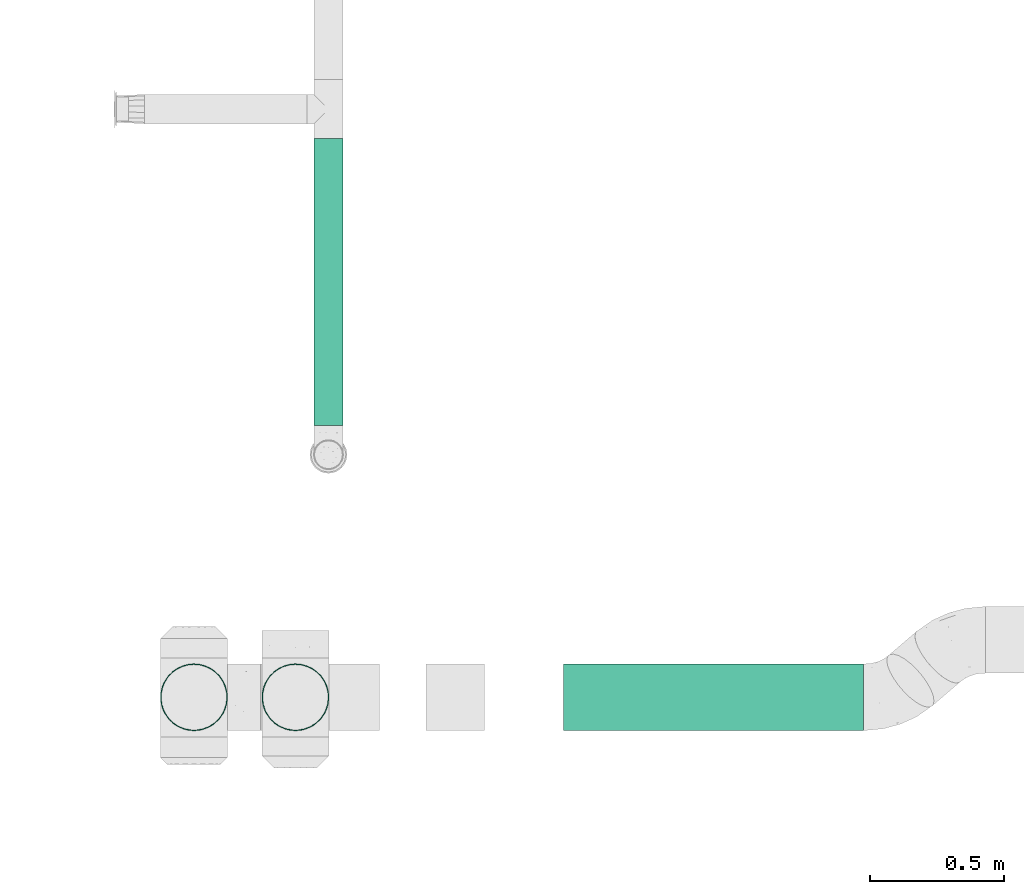
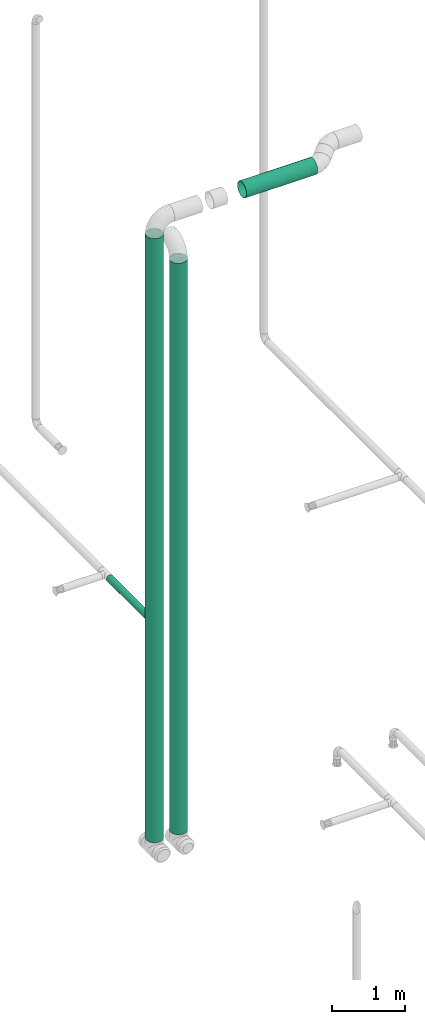
# One storey, part 5 of 123: 4 flow segments.
"""IFC2X3 building model written with IfcOpenShell, lengths in millimetres."""

import ifcopenshell
import ifcopenshell.guid

model = None  # the IFC model being written
_history = None  # IfcOwnerHistory: only IFC2X3 demands one
_inside = {}  # id of a spatial element -> (the spatial element, [elements in it])
_under = {}  # id of a project, library or spatial element -> (it, [spatial elements below it])
_declared = {}  # id of a project -> (the project, [libraries it declares])
_typed = {}  # id of a type object -> (the type object, [elements of that type])
_made_of = {}  # id of a material, layer set ... -> (it, [elements and type objects made of it])


def new_model(schema):
    """Start an empty IFC model of exactly this schema.

    Asked for "IFC4X3", IfcOpenShell would pick the latest addendum, in which some entities
    have other attributes; the version numbers below select the first issue.
    IFC2X3 requires an IfcOwnerHistory on every rooted entity: one is made here for all.
    """
    global model, _history
    if schema == "IFC4X3":
        model = ifcopenshell.file(schema_version=(4, 3, 0, 0))
    else:
        model = ifcopenshell.file(schema=schema)
    _inside.clear()
    _under.clear()
    _declared.clear()
    _typed.clear()
    _made_of.clear()
    _history = None
    if model.schema == "IFC2X3":
        org = make("IfcOrganization", Name="unknown")
        user = make(
            "IfcPersonAndOrganization",
            ThePerson=make("IfcPerson", FamilyName="unknown"),
            TheOrganization=org,
        )
        app = make(
            "IfcApplication",
            ApplicationDeveloper=org,
            Version="unknown",
            ApplicationFullName="unknown",
            ApplicationIdentifier="unknown",
        )
        _history = make(
            "IfcOwnerHistory",
            OwningUser=user,
            OwningApplication=app,
            ChangeAction="ADDED",
            CreationDate=0,
        )
    return model


def make(cls, **values):
    """One entity of the class cls with the attributes given. An attribute that is None is left unset."""
    return model.create_entity(
        cls, **{name: value for name, value in values.items() if value is not None}
    )


def entity(cls, *values):
    """Any entity or typed value of the class cls, its attributes in the order of the schema. None: left unset."""
    e = model.create_entity(cls)
    for i, value in enumerate(values):
        if value is not None:
            e[i] = value
    return e


def rooted(cls, **values):
    """An entity with a GlobalId (a new one), such as an element, a storey or a relation."""
    return make(cls, GlobalId=ifcopenshell.guid.new(), OwnerHistory=_history, **values)


def si_unit(unit_type, name, prefix=None):
    """IfcSIUnit, for example si_unit("LENGTHUNIT", "METRE", prefix="MILLI")."""
    return make("IfcSIUnit", UnitType=unit_type, Prefix=prefix, Name=name)


def converted_unit(unit_type, name, factor, base, dimensions=None, offset=None):
    """IfcConversionBasedUnit, such as the inch: factor (a typed value) times the base unit."""
    return make(
        "IfcConversionBasedUnit"
        if offset is None
        else "IfcConversionBasedUnitWithOffset",
        ConversionOffset=offset,
        Dimensions=None
        if dimensions is None
        else entity("IfcDimensionalExponents", *dimensions),
        UnitType=unit_type,
        Name=name,
        ConversionFactor=make(
            "IfcMeasureWithUnit", ValueComponent=factor, UnitComponent=base
        ),
    )


def derived_unit(unit_type, elements):
    """IfcDerivedUnit: a product of units, each with its exponent."""
    return make(
        "IfcDerivedUnit",
        Elements=[
            make("IfcDerivedUnitElement", Unit=unit, Exponent=power)
            for unit, power in elements
        ],
        UnitType=unit_type,
    )


def assignment(units):
    """IfcUnitAssignment: the units of a project."""
    return None if units is None else make("IfcUnitAssignment", Units=units)


def point(xyz):
    """IfcCartesianPoint."""
    return None if xyz is None else make("IfcCartesianPoint", Coordinates=xyz)


def direction(xyz):
    """IfcDirection."""
    return None if xyz is None else make("IfcDirection", DirectionRatios=xyz)


def frame(location, z_axis=None, x_axis=None):
    """IfcAxis2Placement3D, a coordinate frame: its origin and axes. An axis left out is left unset."""
    return make(
        "IfcAxis2Placement3D",
        Location=point(location),
        Axis=direction(z_axis),
        RefDirection=direction(x_axis),
    )


def frame_2d(location, x_axis=None):
    """IfcAxis2Placement2D, a coordinate frame in the plane: its origin and x axis."""
    return make(
        "IfcAxis2Placement2D", Location=point(location), RefDirection=direction(x_axis)
    )


def origin_with_axes():
    """The frame at (0, 0, 0) with the z axis (0, 0, 1) and the x axis (1, 0, 0) written out."""
    return frame((0.0, 0.0, 0.0), z_axis=(0.0, 0.0, 1.0), x_axis=(1.0, 0.0, 0.0))


def origin_2d_with_axis():
    """The frame at (0, 0) in the plane with the x axis (1, 0) written out."""
    return frame_2d((0.0, 0.0), x_axis=(1.0, 0.0))


def place(relative_to, where):
    """IfcLocalPlacement: puts the frame where relative to a parent placement (None: the world)."""
    return make(
        "IfcLocalPlacement", PlacementRelTo=relative_to, RelativePlacement=where
    )


def context(
    kind, dimensions, precision=None, world=None, true_north=None, identifier=None
):
    """IfcGeometricRepresentationContext, for example the 3D "Model" context."""
    return make(
        "IfcGeometricRepresentationContext",
        ContextIdentifier=identifier,
        ContextType=kind,
        CoordinateSpaceDimension=dimensions,
        Precision=precision,
        WorldCoordinateSystem=world,
        TrueNorth=true_north,
    )


def subcontext(parent, identifier, kind, view, scale=None):
    """IfcGeometricRepresentationSubContext, for example "Body" below "Model"."""
    return make(
        "IfcGeometricRepresentationSubContext",
        ContextIdentifier=identifier,
        ContextType=kind,
        ParentContext=parent,
        TargetScale=scale,
        TargetView=view,
    )


def project(units=None, contexts=None):
    """IfcProject with its units and contexts."""
    return rooted(
        "IfcProject",
        Name="project",
        RepresentationContexts=contexts,
        UnitsInContext=assignment(units),
    )


def spatial(cls, under=None, at=None, **own):
    """A site, building, storey or space (cls), placed at a placement, below another one or the project."""
    s = rooted(cls, ObjectPlacement=at, **own)
    if under is not None:
        _under.setdefault(under.id(), (under, []))[1].append(s)
    return s


def profile(cls, at=None, kind="AREA", **sizes):
    """A parametric profile (cls). Its sizes go by their IFC names, for example OverallWidth=200.0."""
    return make(cls, ProfileType=kind, Position=at, **sizes)


def hollow_circle(**sizes):
    """IfcCircleHollowProfileDef."""
    return profile("IfcCircleHollowProfileDef", **sizes)


def extrude(swept, where, along, depth):
    """IfcExtrudedAreaSolid: the profile swept, set in the frame where, extruded along a direction by depth."""
    return make(
        "IfcExtrudedAreaSolid",
        SweptArea=swept,
        Position=where,
        ExtrudedDirection=direction(along),
        Depth=depth,
    )


def shape(context_of_items, identifier, shape_type, items):
    """IfcShapeRepresentation: the items that make up one representation, for example the "Body"."""
    return make(
        "IfcShapeRepresentation",
        ContextOfItems=context_of_items,
        RepresentationIdentifier=identifier,
        RepresentationType=shape_type,
        Items=items,
    )


def source(mapping_origin, context_of_items, identifier, shape_type, items):
    """IfcRepresentationMap: a shape defined once, which mapped items show again and again."""
    return make(
        "IfcRepresentationMap",
        MappingOrigin=mapping_origin,
        MappedRepresentation=shape(context_of_items, identifier, shape_type, items),
    )


def transform(
    local_origin,
    x_axis=None,
    y_axis=None,
    z_axis=None,
    scale=None,
    scale2=None,
    scale3=None,
    uniform=True,
):
    """IfcCartesianTransformationOperator3D, or its non-uniform kind. x_axis, y_axis, z_axis: its Axis1, 2, 3."""
    if uniform:
        return make(
            "IfcCartesianTransformationOperator3D",
            Axis1=direction(x_axis),
            Axis2=direction(y_axis),
            LocalOrigin=point(local_origin),
            Scale=scale,
            Axis3=direction(z_axis),
        )
    return make(
        "IfcCartesianTransformationOperator3DnonUniform",
        Axis1=direction(x_axis),
        Axis2=direction(y_axis),
        LocalOrigin=point(local_origin),
        Scale=scale,
        Axis3=direction(z_axis),
        Scale2=scale2,
        Scale3=scale3,
    )


def mapped(mapping_source, mapping_target):
    """IfcMappedItem: shows the shape of a source again, moved by a transform."""
    return make(
        "IfcMappedItem", MappingSource=mapping_source, MappingTarget=mapping_target
    )


def material(Name=None, Category=None):
    """IfcMaterial."""
    return make("IfcMaterial", Name=Name, Category=Category)


def layer(
    of_material, thickness, ventilated=None, Name=None, Category=None, Priority=None
):
    """IfcMaterialLayer: one layer of a wall or slab, of a material (None: an air gap)."""
    return make(
        "IfcMaterialLayer",
        Material=of_material,
        LayerThickness=thickness,
        IsVentilated=ventilated,
        Name=Name,
        Category=Category,
        Priority=Priority,
    )


def layer_set(layers, Name=None):
    """IfcMaterialLayerSet."""
    return make("IfcMaterialLayerSet", MaterialLayers=layers, LayerSetName=Name)


def layer_usage(for_layer_set, set_direction, sense, offset, extent=None):
    """IfcMaterialLayerSetUsage: how a layer set lies in its element."""
    return make(
        "IfcMaterialLayerSetUsage",
        ForLayerSet=for_layer_set,
        LayerSetDirection=set_direction,
        DirectionSense=sense,
        OffsetFromReferenceLine=offset,
        ReferenceExtent=extent,
    )


def made_of(thing, what):
    """Note that an element or type object is made of a material, layer set ...; save() writes the relation."""
    if what is not None:
        _made_of.setdefault(what.id(), (what, []))[1].append(thing)
    return thing


def type_object(cls, material=None, **own):
    """A type object (cls), such as IfcWallType, which elements share."""
    return made_of(rooted(cls, **own), material)


def element(
    cls,
    number,
    at=None,
    inside=None,
    cuts=None,
    type_object=None,
    material=None,
    context=None,
    identifier="Body",
    shape_type=None,
    held_by="IfcProductDefinitionShape",
    body=None,
    shapes=None,
    **own,
):
    """One element of the class cls, such as IfcWall. Its Tag is "e" and its number.

    at: its placement. inside: the storey or other place that contains it. cuts: it is an
    opening in that element (IfcRelVoidsElement). A single representation is given by context,
    identifier, shape_type and body (its items); several are given by shapes. held_by: the class
    of the entity that holds the representations. save() writes the other relations.
    """
    e = rooted(cls, Tag="e%d" % number, ObjectPlacement=at, **own)
    if body is not None:
        shapes = [shape(context, identifier, shape_type, body)]
    if shapes is not None:
        e.Representation = make(held_by, Representations=shapes)
    if inside is not None:
        _inside.setdefault(inside.id(), (inside, []))[1].append(e)
    if cuts is not None:
        rooted(
            "IfcRelVoidsElement", RelatingBuildingElement=cuts, RelatedOpeningElement=e
        )
    if type_object is not None:
        _typed.setdefault(type_object.id(), (type_object, []))[1].append(e)
    return made_of(e, material)


def aggregate(whole, parts):
    """IfcRelAggregates: a whole, such as a stair, and the parts it consists of."""
    return rooted("IfcRelAggregates", RelatingObject=whole, RelatedObjects=parts)


def save(model, path):
    """Write the relations noted so far, then the file.

    IfcRelAggregates (storeys below a building ...), IfcRelContainedInSpatialStructure (elements
    in a storey), IfcRelDefinesByType, IfcRelAssociatesMaterial and IfcRelDeclares: one each for
    every whole, place, type object, material and project.
    """
    for whole, parts in _under.values():
        aggregate(whole, parts)
    for where, things in _inside.values():
        rooted(
            "IfcRelContainedInSpatialStructure",
            RelatedElements=things,
            RelatingStructure=where,
        )
    for kind, things in _typed.values():
        rooted("IfcRelDefinesByType", RelatedObjects=things, RelatingType=kind)
    for what, things in _made_of.values():
        rooted("IfcRelAssociatesMaterial", RelatedObjects=things, RelatingMaterial=what)
    for by, libraries in _declared.values():
        rooted("IfcRelDeclares", RelatingContext=by, RelatedDefinitions=libraries)
    model.write(path)


model = new_model("IFC2X3")

# Units and contexts
model_context = context("Model", 3, precision=1e-05, world=origin_with_axes(), true_north=direction((0.0, 1.0)))
body_context = subcontext(model_context, "Body", "Model", "MODEL_VIEW")
ifc_project = project(units=[si_unit("AREAUNIT", "SQUARE_METRE"), si_unit("VOLUMEUNIT", "CUBIC_METRE", prefix="DECI"), si_unit("TIMEUNIT", "SECOND"), si_unit("THERMODYNAMICTEMPERATUREUNIT", "DEGREE_CELSIUS"), si_unit("PRESSUREUNIT", "PASCAL"), si_unit("MASSUNIT", "GRAM", prefix="KILO"), si_unit("LENGTHUNIT", "METRE", prefix="MILLI"), si_unit("POWERUNIT", "WATT"), si_unit("ELECTRICCURRENTUNIT", "AMPERE"), si_unit("ELECTRICVOLTAGEUNIT", "VOLT"), derived_unit("VOLUMETRICFLOWRATEUNIT", [(si_unit("VOLUMEUNIT", "CUBIC_METRE", prefix="DECI"), 1), (si_unit("TIMEUNIT", "SECOND"), -1)]), derived_unit("LINEARVELOCITYUNIT", [(si_unit("LENGTHUNIT", "METRE"), 1), (si_unit("TIMEUNIT", "SECOND"), -1)]), derived_unit("MASSDENSITYUNIT", [(si_unit("MASSUNIT", "GRAM", prefix="KILO"), 1), (si_unit("VOLUMEUNIT", "CUBIC_METRE"), -1)]), converted_unit("PLANEANGLEUNIT", "DEGREE", entity("IfcRatioMeasure", 0.01745), si_unit("PLANEANGLEUNIT", "RADIAN"), dimensions=[0, 0, 0, 0, 0, 0, 0])], contexts=[model_context])

# Site, building, storey
site_placement = place(None, origin_with_axes())
site = spatial("IfcSite", under=ifc_project, at=site_placement, CompositionType="ELEMENT")
building_placement = place(site_placement, origin_with_axes())
building = spatial("IfcBuilding", under=site, at=building_placement, Name="mc-building", CompositionType="ELEMENT")
storey_placement = place(building_placement, origin_with_axes())
storey = spatial("IfcBuildingStorey", under=building, at=storey_placement, Name="1. Korrus", CompositionType="ELEMENT", Elevation=0.0)

# Flow segments
ifc_material = material(Name="FZ1")
ifc_layer = layer(ifc_material, 0.0)
ifc_layer_set = layer_set([ifc_layer], Name="FZ1")
ifc_layer_usage = layer_usage(ifc_layer_set, "AXIS1", "POSITIVE", 0.0)
duct_segment_type_1 = type_object("IfcDuctSegmentType", PredefinedType="RIGIDSEGMENT")
shared_shape_1 = source(origin_with_axes(), body_context, "Body", "SweptSolid", [
    extrude(hollow_circle(Radius=55.0, WallThickness=2.0, at=origin_2d_with_axis()), frame((0.0, 0.0, 0.0), z_axis=(1.0, 0.0, 0.0), x_axis=(0.0, 1.0, 0.0)), (0.0, 0.0, 1.0), 1074.1),
])
flow_segment_1_placement = place(storey_placement, frame((7686.9773, 9767.62755, 2465.0), z_axis=(0.0, 0.0, 1.0), x_axis=(0.0, -1.0, 0.0)))
element("IfcFlowSegment", 1, at=flow_segment_1_placement, inside=storey, type_object=duct_segment_type_1, material=ifc_layer_usage, context=body_context, shape_type="MappedRepresentation", body=[
    mapped(shared_shape_1, transform((0.0, 0.0, 0.0), scale=1.0)),
])
duct_segment_type_2 = type_object("IfcDuctSegmentType", Name="Safe", PredefinedType="RIGIDSEGMENT")
shared_shape_2 = source(origin_with_axes(), body_context, "Body", "SweptSolid", [
    extrude(hollow_circle(Radius=125.0, WallThickness=2.0, at=origin_2d_with_axis()), frame((0.0, 0.0, 0.0), z_axis=(1.0, 0.0, 0.0), x_axis=(0.0, 1.0, 0.0)), (0.0, 0.0, 1.0), 9538.0),
])
flow_segment_2_placement = place(storey_placement, frame((7563.36286, 7675.18604, -420.0), z_axis=(-1.0, 0.0, 0.0), x_axis=(0.0, 0.0, 1.0)))
element("IfcFlowSegment", 2, at=flow_segment_2_placement, inside=storey, type_object=duct_segment_type_2, material=ifc_layer_usage, Name="Safe", context=body_context, shape_type="MappedRepresentation", body=[
    mapped(shared_shape_2, transform((0.0, 0.0, 0.0), scale=1.0)),
])
shared_shape_3 = source(origin_with_axes(), body_context, "Body", "SweptSolid", [
    extrude(hollow_circle(Radius=125.0, WallThickness=2.0, at=origin_2d_with_axis()), frame((0.0, 0.0, 0.0), z_axis=(1.0, 0.0, 0.0), x_axis=(0.0, 1.0, 0.0)), (0.0, 0.0, 1.0), 10084.3),
])
flow_segment_3_placement = place(storey_placement, frame((7183.36286, 7675.18604, -420.0), z_axis=(-1.0, 0.0, 0.0), x_axis=(0.0, 0.0, 1.0)))
element("IfcFlowSegment", 3, at=flow_segment_3_placement, inside=storey, type_object=duct_segment_type_2, material=ifc_layer_usage, Name="Safe", context=body_context, shape_type="MappedRepresentation", body=[
    mapped(shared_shape_3, transform((0.0, 0.0, 0.0), scale=1.0)),
])
shared_shape_4 = source(origin_with_axes(), body_context, "Body", "SweptSolid", [
    extrude(hollow_circle(Radius=125.0, WallThickness=2.0, at=origin_2d_with_axis()), frame((0.0, 0.0, 0.0), z_axis=(1.0, 0.0, 0.0), x_axis=(0.0, 1.0, 0.0)), (0.0, 0.0, 1.0), 1123.0),
])
flow_segment_4_placement = place(storey_placement, frame((8567.02679, 7675.18604, 9914.30701), z_axis=(0.0, 0.0, 1.0), x_axis=(1.0, 0.0, 0.0)))
element("IfcFlowSegment", 4, at=flow_segment_4_placement, inside=storey, type_object=duct_segment_type_2, material=ifc_layer_usage, Name="Safe", context=body_context, shape_type="MappedRepresentation", body=[
    mapped(shared_shape_4, transform((0.0, 0.0, 0.0), scale=1.0)),
])

save(model, "model.ifc")
